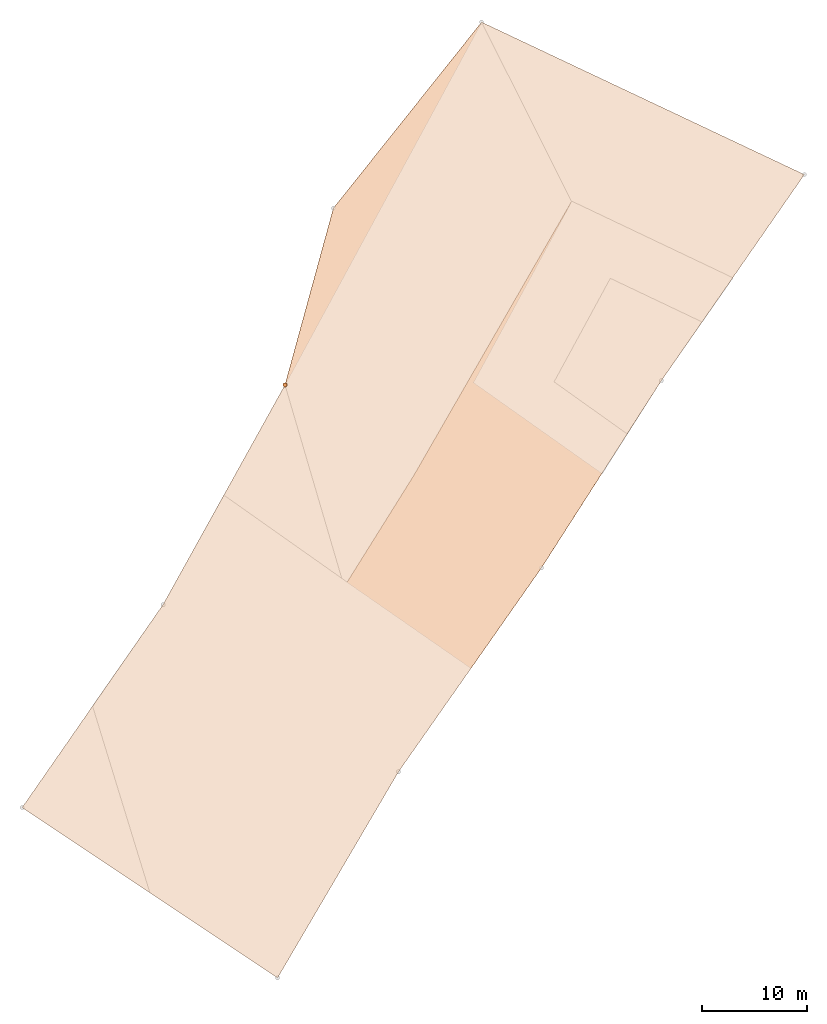
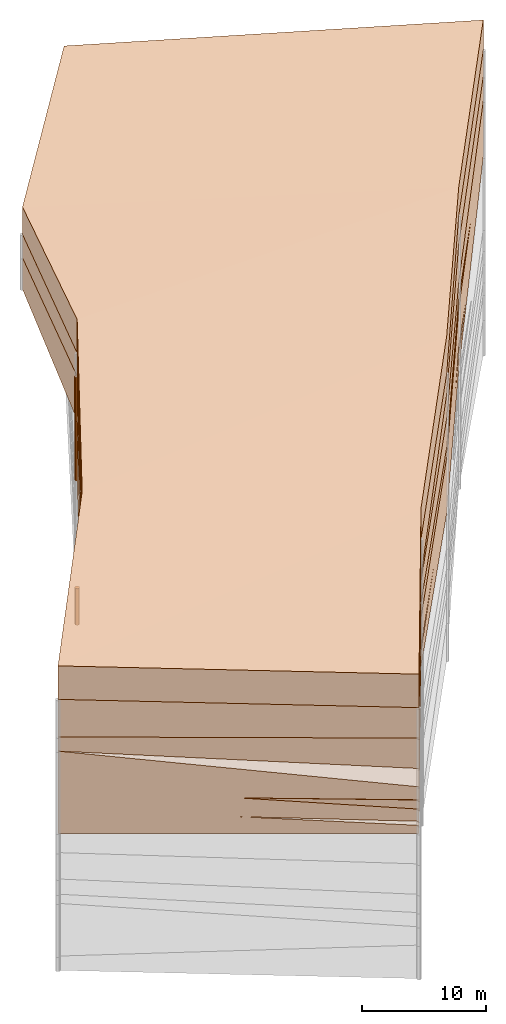
# One storey, part 11 of 24: 8 geographic elements.
"""IFC4 building model written with IfcOpenShell, lengths in metres."""

from ifc_helpers import new_model, entity, si_unit, converted_unit, frame, origin_with_axes, origin_2d_with_axis, place, context, subcontext, project, spatial, polygons, element, save


model = new_model("IFC4")

# Units and contexts
model_context = context("Model", 3, precision=1e-05, world=origin_with_axes())
plan_context = context("Plan", 2, precision=1e-05, world=origin_2d_with_axis())
body_context = subcontext(model_context, "Body", "Model", "MODEL_VIEW")
ifc_project = project(units=[converted_unit("PLANEANGLEUNIT", "degree", entity("IfcReal", 0.0174532925199433), si_unit("PLANEANGLEUNIT", "RADIAN"), dimensions=[0, 0, 0, 0, 0, 0, 0]), si_unit("AREAUNIT", "SQUARE_METRE"), si_unit("VOLUMEUNIT", "CUBIC_METRE"), si_unit("LENGTHUNIT", "METRE")], contexts=[model_context, plan_context])

# Site, building, storey
site_placement = place(None, origin_with_axes())
site = spatial("IfcSite", under=ifc_project, at=site_placement)
building_placement = place(site_placement, origin_with_axes())
building = spatial("IfcBuilding", under=site, at=building_placement, Name="Building")
storey_placement = place(building_placement, origin_with_axes())
storey = spatial("IfcBuildingStorey", under=building, at=storey_placement, Name="Storey")

# Geographic elements
geographic_element_1_placement = place(storey_placement, frame((-6.64915800094604, 19.6997184753418, 18.2000007629395), z_axis=(0.0, 0.0, 1.0), x_axis=(0.848745938684591, -0.528800843008416, 0.0)))
element("IfcGeographicElement", 1, at=geographic_element_1_placement, inside=storey, PredefinedType="NOTDEFINED", context=body_context, shape_type="Tessellation", body=[
    polygons([(-18.1491794586182, 51.726863861084, -2.20000147819519), (-18.1491794586182, 51.726863861084, 0.499999970197678), (-15.5416402816772, 74.2057571411133, -1.89999949932098), (-15.5416421890259, 74.2057647705078, 0.69999885559082), (18.1824722290039, 78.1331329345703, -1.70000064373016), (15.4567575454712, 9.51265048980713, -1.90000140666962), (16.0606708526611, -13.2039785385132, 0.69999885559082), (16.0606708526611, -13.2039785385132, -2.59999918937683), (15.4567556381226, 9.51265048980713, 1.0999983549118), (-13.130428314209, -12.3041467666626, -3.10000014305115), (-13.130428314209, -12.3041467666626, 0.199998840689659), (-11.9630832672119, 11.1625785827637, -1.99999988079071), (18.1824722290039, 78.1331253051758, 1.29999911785126), (17.0040245056152, 54.3060111999512, 1.49999809265137), (16.7409706115723, 33.1700096130371, 1.60000026226044), (-13.1695642471313, 35.035457611084, 1.19899940490723), (-11.9630851745605, 11.1625785827637, 0.999999940395355), (17.0040245056152, 54.3060111999512, -1.30000114440918), (-13.169563293457, 35.0354537963867, -2.09900069236755), (16.7409687042236, 33.1700134277344, -2.10000014305115)], [[[4, 5, 3]], [[13, 14, 18, 5]], [[11, 17, 12, 10]], [[15, 18, 14]], [[11, 9, 17]], [[20, 12, 19]], [[16, 14, 2]], [[3, 18, 1]], [[4, 14, 13]], [[18, 19, 1]], [[15, 17, 9]], [[9, 20, 15]], [[16, 2, 1, 19]], [[8, 11, 10]], [[6, 10, 12]], [[2, 3, 1]], [[7, 6, 9]], [[17, 19, 12]], [[4, 13, 5]], [[15, 20, 18]], [[11, 7, 9]], [[20, 6, 12]], [[16, 15, 14]], [[3, 5, 18]], [[4, 2, 14]], [[18, 20, 19]], [[15, 16, 17]], [[9, 6, 20]], [[8, 7, 11]], [[6, 8, 10]], [[2, 4, 3]], [[7, 8, 6]], [[17, 16, 19]]]),
])
geographic_element_2_placement = place(storey_placement, frame((-6.09105730056763, 19.0666542053223, 15.3662185668945), z_axis=(0.0, 0.0, 1.0), x_axis=(0.605714798641932, 0.795681835098781, 0.0)))
element("IfcGeographicElement", 2, at=geographic_element_2_placement, inside=storey, PredefinedType="NOTDEFINED", context=body_context, shape_type="Tessellation", body=[
    polygons([(-11.4815444946289, -16.3955001831055, -2.76621699333191), (-13.3103704452515, 12.7521448135376, -3.96621870994568), (-13.3103704452515, 12.7521467208862, -0.266218155622482), (72.5967788696289, 23.2277584075928, -1.56621730327606), (49.9726409912109, 23.725715637207, -1.66621661186218), (49.9726409912109, 23.725715637207, 0.633780658245087), (72.5967788696289, 23.2277584075928, 0.933782517910004), (79.6548538208008, -9.98253726959229, -1.46621787548065), (11.0795383453369, -13.6738271713257, -2.76621866226196), (-11.4815425872803, -16.3955001831055, 0.233782753348351), (55.8217697143555, -11.0332765579224, -1.26621794700623), (10.1628646850586, 13.7803087234497, 0.833781361579895), (11.0795373916626, -13.6738262176514, 0.933779835700989), (79.6548614501953, -9.9825325012207, 1.13378131389618), (55.8217658996582, -11.033278465271, 1.53378021717072), (33.8189010620117, 17.2098445892334, 0.734781384468079), (34.7534828186035, -12.7442312240601, 0.733781933784485), (10.1628646850586, 13.7803087234497, -3.36621809005737), (34.7534866333008, -12.7442293167114, -1.26621794700623), (33.8189010620117, 17.2098445892334, -1.56321775913239)], [[[19, 13, 9]], [[14, 11, 8]], [[20, 6, 5]], [[19, 11, 15, 17]], [[15, 7, 6]], [[2, 9, 1]], [[16, 15, 6]], [[18, 19, 9]], [[12, 17, 16]], [[20, 11, 19]], [[4, 11, 5]], [[9, 13, 10, 1]], [[10, 3, 2, 1]], [[3, 12, 18, 2]], [[12, 20, 18]], [[3, 13, 12]], [[6, 7, 4, 5]], [[7, 8, 4]], [[19, 17, 13]], [[14, 15, 11]], [[20, 16, 6]], [[15, 14, 7]], [[2, 18, 9]], [[16, 17, 15]], [[18, 20, 19]], [[12, 13, 17]], [[20, 5, 11]], [[4, 8, 11]], [[12, 16, 20]], [[3, 10, 13]], [[7, 14, 8]]]),
])
geographic_element_3_placement = place(storey_placement, frame((-5.96353912353516, 18.549129486084, 6.34844017028809), z_axis=(0.0, 0.0, 1.0), x_axis=(0.81700617141835, -0.576628923888084, 0.0)))
element("IfcGeographicElement", 3, at=geographic_element_3_placement, inside=storey, PredefinedType="NOTDEFINED", context=body_context, shape_type="Tessellation", body=[
    polygons([(-20.9974346160889, 73.7364654541016, 1.05156171321869), (-6.37303066253662, -6.42467784881592, -1.59844017028809), (-13.8074789047241, 11.0024585723877, -1.24844026565552), (-20.9974308013916, 73.736457824707, 3.25156211853027), (12.4457817077637, 79.5923690795898, -0.34843921661377), (13.6900873184204, 10.5932197570801, 3.59980535507202), (13.6618566513062, 10.9285478591919, 3.63929176330566), (13.6618566513062, 10.9285478591919, 5.75155925750732), (15.568211555481, -11.7160053253174, 1.45156145095825), (15.5682106018066, -11.7160043716431, 0.169029697775841), (-1.35994815826416, 22.8476676940918, -0.948440074920654), (13.6618566513062, 10.9285478591919, -2.74844098091125), (13.6618566513062, 10.9285478591919, -1.14844083786011), (15.5682106018066, -11.7160043716431, -0.724769651889801), (-13.626425743103, -12.4925842285156, -4.44844055175781), (0.970892786979675, -12.1042928695679, -0.298439562320709), (-13.626425743103, -12.4925842285156, 3.65155959129333), (-13.8074798583984, 11.002459526062, -2.84844017028809), (13.5865421295166, 34.6206169128418, 5.35456037521362), (-13.8074779510498, 11.0024585723877, 1.95155894756317), (13.586540222168, 34.6206169128418, -4.04243803024292), (-16.3817501068115, 34.7667770385742, -2.74144124984741), (13.6618566513062, 10.9285478591919, 2.16074848175049), (13.5865411758423, 34.6206169128418, 1.4637678861618), (12.636417388916, 55.7369003295898, 3.95156073570251), (13.5865411758423, 34.6206169128418, 2.45087766647339), (12.8929653167725, 50.0352783203125, -2.7466356754303), (12.6364221572876, 55.7369003295898, -4.7484393119812), (-16.3817501068115, 34.7667846679688, 3.15655946731567), (12.5410985946655, 67.6646423339844, 1.85155951976776), (12.5821380615234, 62.5297546386719, -2.74844026565552), (12.6358518600464, 55.8078536987305, 1.35736930370331), (12.4457817077637, 79.5923690795898, 5.15156078338623), (-4.18050241470337, 64.7366790771484, 1.85155951976776), (12.6358518600464, 55.8078536987305, 2.34575176239014), (-1.39760553836823, 34.6936988830566, 1.95155990123749), (-0.0728111788630486, 10.9655027389526, 2.90155959129333), (12.8960647583008, 49.7227897644043, -2.76844024658203), (12.6364212036133, 55.7369003295898, -3.13321948051453), (4.36350059509277, 49.758430480957, -2.74844026565552), (3.05499243736267, 60.8876571655273, -2.74844026565552), (12.6364212036133, 55.7369003295898, -2.35718083381653), (12.6355352401733, 55.8476486206055, -2.3566517829895), (12.6355361938477, 55.8476486206055, -3.14022731781006), (15.5682096481323, -11.7160015106201, -3.14843726158142), (12.6423559188843, 55.6049995422363, -2.35759830474854), (13.6518440246582, 14.0782699584961, -0.800657331943512), (13.6236047744751, 22.9614772796631, -0.948439836502075), (15.5682067871094, -11.7159986495972, -1.94843733310699), (13.6618518829346, 10.9285430908203, -0.74844092130661), (2.06520700454712, 10.9597501754761, -0.5795738697052), (-13.8074789047241, 11.0024585723877, -0.348440647125244), (-13.8074789047241, 11.0024585723877, -0.457723498344421), (15.5682039260864, -11.7159996032715, -2.34843683242798), (11.1614723205566, -11.8332214355469, -2.28806042671204), (9.8250036239624, -11.8687715530396, -2.02712678909302), (0.970889091491699, -12.1042928695679, -2.14843964576721), (13.6236114501953, 22.9593849182129, -0.948405027389526), (13.6236047744751, 22.9614791870117, -0.948439836502075), (13.6236047744751, 22.9614791870117, -0.948439836502075), (15.5682039260864, -11.7159996032715, -2.34843683242798), (13.7070989608765, 10.3910789489746, -0.776922643184662), (13.6618518829346, 10.9285430908203, -0.74844092130661), (13.6618518829346, 10.9285430908203, -0.74844092130661), (13.6618518829346, 10.9285478591919, -0.748440682888031), (13.6618280410767, 10.936182975769, -0.748567581176758), (-13.8074789047241, 11.002459526062, -0.586666285991669), (-13.8074789047241, 11.0024585723877, -0.348440676927567), (-13.8074779510498, 11.0023078918457, -1.24843442440033), (-13.7169647216797, -0.743510663509369, -0.801095187664032), (-15.0905656814575, 22.8472442626953, -0.798516094684601), (-13.8075246810913, 11.0028800964355, -1.24842429161072), (15.5681943893433, -11.7159986495972, -1.94843745231628), (15.5682048797607, -11.7159986495972, -1.94843733310699), (12.9731311798096, -11.7850313186646, -1.98399341106415), (10.2083377838135, -11.8585748672485, -2.02187466621399), (11.161473274231, -11.8332214355469, -2.28806042671204), (15.5681972503662, -11.7159996032715, -2.34843683242798), (7.8209285736084, -11.922080039978, -2.05458521842957), (0.970890402793884, -12.1042928695679, -2.14843964576721), (3.88099813461304, -12.0268831253052, -2.18831086158752), (0.97088897228241, -12.1042928695679, -2.14843964576721), (-13.8074750900269, 11.0024585723877, -1.24844026565552), (-13.8074750900269, 11.0024585723877, -1.24844026565552), (13.6235961914062, 22.9614734649658, -0.948439955711365), (13.041205406189, 10.9302129745483, -0.739403247833252), (15.5682029724121, -11.7159957885742, -1.94843721389771), (2.06520652770996, 10.9597492218018, -0.579573929309845)], [[[29, 1, 22]], [[32, 36, 24]], [[8, 6, 7]], [[25, 26, 35]], [[21, 18, 22]], [[17, 15, 16]], [[21, 24, 60]], [[48, 13, 60]], [[8, 9, 10, 6]], [[27, 24, 21]], [[19, 20, 8]], [[61, 12, 13]], [[54, 61, 13]], [[14, 49, 62]], [[62, 50, 63]], [[23, 63, 64, 24]], [[63, 50, 64]], [[24, 64, 65]], [[64, 50, 66, 65]], [[16, 23, 37]], [[37, 24, 36]], [[8, 17, 9]], [[22, 28, 21]], [[25, 29, 19]], [[19, 7, 26]], [[41, 42, 46, 40]], [[30, 32, 31]], [[18, 53, 52, 67]], [[20, 68, 52]], [[15, 17, 70]], [[6, 16, 37]], [[35, 36, 34]], [[34, 32, 30]], [[34, 30, 35]], [[4, 5, 1]], [[25, 4, 29]], [[41, 43, 42]], [[41, 31, 43]], [[41, 44, 31]], [[20, 29, 22, 18, 67, 72, 71, 68]], [[1, 28, 22]], [[13, 2, 54]], [[16, 49, 14]], [[73, 74, 16]], [[16, 10, 9]], [[76, 75, 16, 56]], [[78, 77, 45, 61]], [[61, 54, 78]], [[17, 16, 9]], [[57, 80, 82]], [[77, 55, 81]], [[32, 46, 42]], [[32, 24, 27]], [[28, 27, 21]], [[39, 27, 28]], [[32, 27, 46]], [[44, 39, 28]], [[33, 25, 30]], [[30, 25, 35]], [[31, 44, 28]], [[28, 5, 31]], [[31, 32, 43]], [[5, 30, 31]], [[33, 30, 5]], [[12, 15, 18]], [[37, 7, 6]], [[39, 40, 27]], [[37, 26, 7]], [[44, 41, 39]], [[40, 46, 27]], [[40, 27, 38]], [[42, 43, 32]], [[74, 2, 49]], [[79, 2, 76, 56]], [[2, 80, 57]], [[2, 57, 81]], [[2, 81, 55, 54]], [[48, 85, 13]], [[66, 50, 52]], [[58, 47, 66]], [[51, 52, 86]], [[50, 86, 52]], [[62, 86, 50]], [[62, 49, 87]], [[88, 2, 52]], [[3, 53, 69]], [[2, 74, 73]], [[76, 2, 73, 75]], [[2, 79, 82]], [[83, 3, 2]], [[61, 13, 2, 78]], [[2, 13, 83]], [[68, 71, 11, 52]], [[80, 2, 82]], [[77, 78, 2, 81]], [[3, 83, 84, 11]], [[11, 84, 13]], [[72, 3, 11, 71]], [[52, 53, 67]], [[70, 52, 2]], [[70, 2, 3, 69]], [[29, 4, 1]], [[32, 34, 36]], [[25, 19, 26]], [[21, 12, 18]], [[13, 12, 60]], [[12, 21, 60]], [[24, 47, 58]], [[60, 59, 13]], [[24, 58, 60]], [[13, 59, 60]], [[60, 58, 48]], [[19, 29, 20]], [[61, 45, 12]], [[62, 63, 23]], [[23, 14, 62]], [[65, 66, 24]], [[66, 47, 24]], [[16, 14, 23]], [[37, 23, 24]], [[8, 20, 17]], [[19, 8, 7]], [[69, 53, 18]], [[17, 20, 70]], [[20, 52, 70]], [[70, 69, 18]], [[70, 18, 15]], [[6, 10, 16]], [[35, 26, 36]], [[4, 33, 5]], [[25, 33, 4]], [[1, 5, 28]], [[74, 49, 16]], [[16, 75, 73]], [[55, 77, 78]], [[54, 55, 78]], [[82, 79, 16]], [[79, 56, 16]], [[15, 45, 81]], [[45, 77, 81]], [[15, 81, 57]], [[82, 16, 15]], [[82, 15, 57]], [[12, 45, 15]], [[39, 41, 40]], [[37, 36, 26]], [[48, 11, 85]], [[52, 11, 66]], [[11, 48, 58]], [[58, 66, 11]], [[88, 52, 51]], [[51, 86, 62]], [[49, 2, 87]], [[87, 88, 51]], [[51, 62, 87]], [[88, 87, 2]], [[13, 85, 11]], [[84, 83, 13]], [[3, 72, 67]], [[53, 3, 67]]]),
])
geographic_element_4_placement = place(storey_placement, frame((-6.07823514938354, 18.4122753143311, 13.8235921859741), z_axis=(0.0, 0.0, 1.0), x_axis=(0.831565969542363, -0.555425997140096, 0.0)))
element("IfcGeographicElement", 4, at=geographic_element_4_placement, inside=storey, PredefinedType="NOTDEFINED", context=body_context, shape_type="Tessellation", body=[
    polygons([(-19.0747299194336, 74.4295959472656, -4.22358989715576), (-19.0747299194336, 74.4295959472656, -0.0235910397022963), (14.5080213546753, 79.4234619140625, -2.32359099388123), (15.2811098098755, -11.9350118637085, -4.22359085083008), (13.9577665328979, 10.7510805130005, -1.72359263896942), (13.9577665328979, 10.7510805130005, -1.22359263896942), (15.2811098098755, -11.9350118637085, -1.22359085083008), (-13.9238433837891, -11.9604930877686, -3.82359194755554), (-13.9238414764404, -11.9604921340942, -2.42359256744385), (-13.5005807876587, 11.5314359664917, -1.82359206676483), (14.508017539978, 79.4234619140625, 0.0764083787798882), (14.0850687026978, 55.5709800720215, 0.276408165693283), (-20.968770980835, 51.8793678283691, -0.123591415584087), (-15.4628200531006, 35.3541107177734, -0.0205917339771986), (14.4918041229248, 34.4372482299805, 0.276408165693283), (14.0850696563721, 55.5709800720215, -3.52359080314636), (-17.2689971923828, 54.8919944763184, -4.27109956741333), (-15.462818145752, 35.3541069030762, -4.31859159469604), (14.4918022155762, 34.4372482299805, -2.12059116363525), (-20.9687690734863, 51.8793678283691, -3.22359013557434)], [[[12, 19, 16]], [[9, 6, 10]], [[12, 3, 11]], [[10, 15, 14]], [[5, 8, 10]], [[2, 12, 11]], [[16, 18, 17]], [[19, 10, 18]], [[16, 1, 3]], [[14, 12, 13]], [[2, 11, 3, 1]], [[14, 13, 20, 18]], [[6, 7, 4, 5]], [[9, 10, 8]], [[10, 14, 18]], [[15, 6, 5, 19]], [[8, 4, 7, 9]], [[1, 17, 20]], [[20, 17, 18]], [[2, 20, 13]], [[12, 15, 19]], [[9, 7, 6]], [[12, 16, 3]], [[10, 6, 15]], [[5, 4, 8]], [[2, 13, 12]], [[16, 19, 18]], [[19, 5, 10]], [[16, 17, 1]], [[14, 15, 12]], [[2, 1, 20]]]),
])
geographic_element_5_placement = place(storey_placement, frame((-5.96353912353516, 18.549129486084, 6.34844017028809), z_axis=(0.0, 0.0, 1.0), x_axis=(0.806372566444084, -0.591407883010009, 0.0)))
element("IfcGeographicElement", 5, at=geographic_element_5_placement, inside=storey, PredefinedType="NOTDEFINED", context=body_context, shape_type="Tessellation", body=[
    polygons([(11.3071136474609, 67.8817520141602, 1.85155951976776), (11.619574546814, 55.9577178955078, 1.35156059265137), (11.619574546814, 55.9577178955078, 2.35156059265137), (15.7789316177368, -11.430624961853, -0.748437881469727), (13.4606266021729, 11.1754655838013, 2.1515588760376), (13.4606266021729, 11.1754665374756, 3.6515588760376), (15.7789316177368, -11.430624961853, 0.151561722159386), (1.1911039352417, -12.0846128463745, -0.298439979553223), (-0.272438019514084, 10.9623594284058, 2.90155959129333), (12.9539842605591, 34.8622398376465, 2.4575617313385), (-2.0290105342865, 34.6625022888184, 1.95155990123749), (-5.35841178894043, 64.6498336791992, 1.85155951976776), (12.9539813995361, 34.8622436523438, 1.45756137371063)], [[[1, 3, 2]], [[2, 11, 12]], [[8, 4, 7]], [[6, 7, 4, 5]], [[5, 8, 9]], [[3, 11, 10]], [[10, 5, 13]], [[12, 1, 2]], [[12, 3, 1]], [[8, 6, 9]], [[9, 10, 11]], [[13, 9, 11]], [[3, 13, 2]], [[2, 13, 11]], [[5, 4, 8]], [[3, 12, 11]], [[10, 6, 5]], [[8, 7, 6]], [[9, 6, 10]], [[13, 5, 9]], [[3, 10, 13]]]),
])
geographic_element_6_placement = place(storey_placement, frame((0.699999988079071, 56.4000015258789, 6.55599975585938), z_axis=(0.0, 0.0, 1.0), x_axis=(1.0, 0.0, 0.0)))
element("IfcGeographicElement", 6, at=geographic_element_6_placement, inside=storey, PredefinedType="NOTDEFINED", context=body_context, shape_type="Tessellation", body=[
    polygons([(0.0, 0.0, -2.94899988174438), (0.0390180610120296, 0.196157038211823, -2.94899988174438), (0.0, 0.199999988079071, -2.94899988174438), (0.0, 0.0, 2.94899988174438), (0.0, 0.199999988079071, 2.94899988174438), (0.0390180610120296, 0.196157038211823, 2.94899988174438), (0.0765366926789284, 0.18477588891983, -2.94899988174438), (0.0765366926789284, 0.18477588891983, 2.94899988174438), (0.111114047467709, 0.166293919086456, -2.94899988174438), (0.111114047467709, 0.166293919086456, 2.94899988174438), (0.141421362757683, 0.141421362757683, -2.94899988174438), (0.141421362757683, 0.141421362757683, 2.94899988174438), (0.166293919086456, 0.111114047467709, -2.94899988174438), (0.166293919086456, 0.111114047467709, 2.94899988174438), (0.18477588891983, 0.0765366926789284, -2.94899988174438), (0.18477588891983, 0.0765366926789284, 2.94899988174438), (0.196157038211823, 0.0390180610120296, -2.94899988174438), (0.196157038211823, 0.0390180610120296, 2.94899988174438), (0.199999988079071, 0.0, -2.94899988174438), (0.199999988079071, 0.0, 2.94899988174438), (0.196157038211823, -0.0390180610120296, -2.94899988174438), (0.196157038211823, -0.0390180610120296, 2.94899988174438), (0.18477588891983, -0.0765366926789284, -2.94899988174438), (0.18477588891983, -0.0765366926789284, 2.94899988174438), (0.166293919086456, -0.111114047467709, -2.94899988174438), (0.166293919086456, -0.111114047467709, 2.94899988174438), (0.141421362757683, -0.141421362757683, -2.94899988174438), (0.141421362757683, -0.141421362757683, 2.94899988174438), (0.111114047467709, -0.166293919086456, -2.94899988174438), (0.111114047467709, -0.166293919086456, 2.94899988174438), (0.0765366926789284, -0.18477588891983, -2.94899988174438), (0.0765366926789284, -0.18477588891983, 2.94899988174438), (0.0390180610120296, -0.196157038211823, -2.94899988174438), (0.0390180610120296, -0.196157038211823, 2.94899988174438), (0.0, -0.199999988079071, -2.94899988174438), (0.0, -0.199999988079071, 2.94899988174438), (-0.0390180610120296, -0.196157038211823, -2.94899988174438), (-0.0390180610120296, -0.196157038211823, 2.94899988174438), (-0.0765366926789284, -0.18477588891983, -2.94899988174438), (-0.0765366926789284, -0.18477588891983, 2.94899988174438), (-0.111114047467709, -0.166293919086456, -2.94899988174438), (-0.111114047467709, -0.166293919086456, 2.94899988174438), (-0.141421362757683, -0.141421362757683, -2.94899988174438), (-0.141421362757683, -0.141421362757683, 2.94899988174438), (-0.166293919086456, -0.111114047467709, -2.94899988174438), (-0.166293919086456, -0.111114047467709, 2.94899988174438), (-0.18477588891983, -0.0765366926789284, -2.94899988174438), (-0.18477588891983, -0.0765366926789284, 2.94899988174438), (-0.196157038211823, -0.0390180610120296, -2.94899988174438), (-0.196157038211823, -0.0390180610120296, 2.94899988174438), (-0.199999988079071, 0.0, -2.94899988174438), (-0.199999988079071, 0.0, 2.94899988174438), (-0.196157038211823, 0.0390180610120296, -2.94899988174438), (-0.196157038211823, 0.0390180610120296, 2.94899988174438), (-0.18477588891983, 0.0765366926789284, -2.94899988174438), (-0.18477588891983, 0.0765366926789284, 2.94899988174438), (-0.166293919086456, 0.111114047467709, -2.94899988174438), (-0.166293919086456, 0.111114047467709, 2.94899988174438), (-0.141421362757683, 0.141421362757683, -2.94899988174438), (-0.141421362757683, 0.141421362757683, 2.94899988174438), (-0.111114047467709, 0.166293919086456, -2.94899988174438), (-0.111114047467709, 0.166293919086456, 2.94899988174438), (-0.0765366926789284, 0.18477588891983, -2.94899988174438), (-0.0765366926789284, 0.18477588891983, 2.94899988174438), (-0.0390180610120296, 0.196157038211823, -2.94899988174438), (-0.0390180610120296, 0.196157038211823, 2.94899988174438)], [[[3, 2, 1]], [[6, 5, 4]], [[28, 30, 29, 27]], [[2, 7, 1]], [[8, 6, 4]], [[36, 38, 37, 35]], [[7, 9, 1]], [[10, 8, 4]], [[56, 58, 57, 55]], [[9, 11, 1]], [[12, 10, 4]], [[58, 60, 59, 57]], [[11, 13, 1]], [[12, 4, 14]], [[54, 56, 55, 53]], [[1, 13, 15]], [[14, 4, 16]], [[10, 12, 11, 9]], [[1, 15, 17]], [[4, 18, 16]], [[60, 62, 61, 59]], [[1, 17, 19]], [[4, 20, 18]], [[16, 18, 17, 15]], [[1, 19, 21]], [[20, 4, 22]], [[18, 20, 19, 17]], [[1, 21, 23]], [[4, 24, 22]], [[20, 22, 21, 19]], [[1, 23, 25]], [[24, 4, 26]], [[22, 24, 23, 21]], [[27, 1, 25]], [[26, 4, 28]], [[24, 26, 25, 23]], [[1, 27, 29]], [[28, 4, 30]], [[62, 64, 63, 61]], [[1, 29, 31]], [[4, 32, 30]], [[64, 66, 65, 63]], [[1, 31, 33]], [[4, 34, 32]], [[30, 32, 31, 29]], [[1, 33, 35]], [[4, 36, 34]], [[8, 10, 9, 7]], [[1, 35, 37]], [[4, 38, 36]], [[32, 34, 33, 31]], [[1, 37, 39]], [[4, 40, 38]], [[6, 8, 7, 2]], [[1, 39, 41]], [[4, 42, 40]], [[38, 40, 39, 37]], [[43, 1, 41]], [[4, 44, 42]], [[40, 42, 41, 39]], [[45, 1, 43]], [[46, 44, 4]], [[42, 44, 43, 41]], [[47, 1, 45]], [[4, 48, 46]], [[44, 46, 45, 43]], [[47, 49, 1]], [[50, 48, 4]], [[46, 48, 47, 45]], [[51, 1, 49]], [[52, 50, 4]], [[48, 50, 49, 47]], [[51, 53, 1]], [[4, 54, 52]], [[66, 5, 3, 65]], [[53, 55, 1]], [[56, 54, 4]], [[52, 54, 53, 51]], [[57, 1, 55]], [[4, 58, 56]], [[57, 59, 1]], [[60, 58, 4]], [[34, 36, 35, 33]], [[59, 61, 1]], [[62, 60, 4]], [[14, 16, 15, 13]], [[61, 63, 1]], [[64, 62, 4]], [[26, 28, 27, 25]], [[63, 65, 1]], [[66, 64, 4]], [[5, 6, 2, 3]], [[65, 3, 1]], [[5, 66, 4]], [[50, 52, 51, 49]], [[12, 14, 13, 11]]]),
])
geographic_element_7_placement = place(storey_placement, frame((0.699999988079071, 56.4000015258789, 11.6540002822876), z_axis=(0.0, 0.0, 1.0), x_axis=(1.0, 0.0, 0.0)))
element("IfcGeographicElement", 7, at=geographic_element_7_placement, inside=storey, PredefinedType="NOTDEFINED", context=body_context, shape_type="Tessellation", body=[
    polygons([(0.0, 0.0, -2.1489999294281), (0.0390180610120296, 0.196157038211823, -2.1489999294281), (0.0, 0.199999988079071, -2.1489999294281), (0.0, 0.0, 2.1489999294281), (0.0, 0.199999988079071, 2.1489999294281), (0.0390180610120296, 0.196157038211823, 2.1489999294281), (0.0765366926789284, 0.18477588891983, -2.1489999294281), (0.0765366926789284, 0.18477588891983, 2.1489999294281), (0.111114047467709, 0.166293919086456, -2.1489999294281), (0.111114047467709, 0.166293919086456, 2.1489999294281), (0.141421362757683, 0.141421362757683, -2.1489999294281), (0.141421362757683, 0.141421362757683, 2.1489999294281), (0.166293919086456, 0.111114047467709, -2.1489999294281), (0.166293919086456, 0.111114047467709, 2.1489999294281), (0.18477588891983, 0.0765366926789284, -2.1489999294281), (0.18477588891983, 0.0765366926789284, 2.1489999294281), (0.196157038211823, 0.0390180610120296, -2.1489999294281), (0.196157038211823, 0.0390180610120296, 2.1489999294281), (0.199999988079071, 0.0, -2.1489999294281), (0.199999988079071, 0.0, 2.1489999294281), (0.196157038211823, -0.0390180610120296, -2.1489999294281), (0.196157038211823, -0.0390180610120296, 2.1489999294281), (0.18477588891983, -0.0765366926789284, -2.1489999294281), (0.18477588891983, -0.0765366926789284, 2.1489999294281), (0.166293919086456, -0.111114047467709, -2.1489999294281), (0.166293919086456, -0.111114047467709, 2.1489999294281), (0.141421362757683, -0.141421362757683, -2.1489999294281), (0.141421362757683, -0.141421362757683, 2.1489999294281), (0.111114047467709, -0.166293919086456, -2.1489999294281), (0.111114047467709, -0.166293919086456, 2.1489999294281), (0.0765366926789284, -0.18477588891983, -2.1489999294281), (0.0765366926789284, -0.18477588891983, 2.1489999294281), (0.0390180610120296, -0.196157038211823, -2.1489999294281), (0.0390180610120296, -0.196157038211823, 2.1489999294281), (0.0, -0.199999988079071, -2.1489999294281), (0.0, -0.199999988079071, 2.1489999294281), (-0.0390180610120296, -0.196157038211823, -2.1489999294281), (-0.0390180610120296, -0.196157038211823, 2.1489999294281), (-0.0765366926789284, -0.18477588891983, -2.1489999294281), (-0.0765366926789284, -0.18477588891983, 2.1489999294281), (-0.111114047467709, -0.166293919086456, -2.1489999294281), (-0.111114047467709, -0.166293919086456, 2.1489999294281), (-0.141421362757683, -0.141421362757683, -2.1489999294281), (-0.141421362757683, -0.141421362757683, 2.1489999294281), (-0.166293919086456, -0.111114047467709, -2.1489999294281), (-0.166293919086456, -0.111114047467709, 2.1489999294281), (-0.18477588891983, -0.0765366926789284, -2.1489999294281), (-0.18477588891983, -0.0765366926789284, 2.1489999294281), (-0.196157038211823, -0.0390180610120296, -2.1489999294281), (-0.196157038211823, -0.0390180610120296, 2.1489999294281), (-0.199999988079071, 0.0, -2.1489999294281), (-0.199999988079071, 0.0, 2.1489999294281), (-0.196157038211823, 0.0390180610120296, -2.1489999294281), (-0.196157038211823, 0.0390180610120296, 2.1489999294281), (-0.18477588891983, 0.0765366926789284, -2.1489999294281), (-0.18477588891983, 0.0765366926789284, 2.1489999294281), (-0.166293919086456, 0.111114047467709, -2.1489999294281), (-0.166293919086456, 0.111114047467709, 2.1489999294281), (-0.141421362757683, 0.141421362757683, -2.1489999294281), (-0.141421362757683, 0.141421362757683, 2.1489999294281), (-0.111114047467709, 0.166293919086456, -2.1489999294281), (-0.111114047467709, 0.166293919086456, 2.1489999294281), (-0.0765366926789284, 0.18477588891983, -2.1489999294281), (-0.0765366926789284, 0.18477588891983, 2.1489999294281), (-0.0390180610120296, 0.196157038211823, -2.1489999294281), (-0.0390180610120296, 0.196157038211823, 2.1489999294281)], [[[3, 2, 1]], [[6, 5, 4]], [[28, 30, 29, 27]], [[2, 7, 1]], [[8, 6, 4]], [[64, 66, 65, 63]], [[7, 9, 1]], [[10, 8, 4]], [[9, 11, 1]], [[12, 10, 4]], [[6, 8, 7, 2]], [[1, 11, 13]], [[12, 4, 14]], [[66, 5, 3, 65]], [[1, 13, 15]], [[4, 16, 14]], [[12, 14, 13, 11]], [[1, 15, 17]], [[4, 18, 16]], [[14, 16, 15, 13]], [[1, 17, 19]], [[4, 20, 18]], [[16, 18, 17, 15]], [[1, 19, 21]], [[4, 22, 20]], [[18, 20, 19, 17]], [[1, 21, 23]], [[22, 4, 24]], [[20, 22, 21, 19]], [[1, 23, 25]], [[4, 26, 24]], [[22, 24, 23, 21]], [[27, 1, 25]], [[4, 28, 26]], [[24, 26, 25, 23]], [[1, 27, 29]], [[28, 4, 30]], [[26, 28, 27, 25]], [[1, 29, 31]], [[4, 32, 30]], [[5, 6, 2, 3]], [[1, 31, 33]], [[4, 34, 32]], [[30, 32, 31, 29]], [[1, 33, 35]], [[4, 36, 34]], [[8, 10, 9, 7]], [[1, 35, 37]], [[4, 38, 36]], [[32, 34, 33, 31]], [[1, 37, 39]], [[4, 40, 38]], [[36, 38, 37, 35]], [[1, 39, 41]], [[4, 42, 40]], [[38, 40, 39, 37]], [[43, 1, 41]], [[4, 44, 42]], [[40, 42, 41, 39]], [[43, 45, 1]], [[46, 44, 4]], [[42, 44, 43, 41]], [[45, 47, 1]], [[48, 46, 4]], [[44, 46, 45, 43]], [[49, 1, 47]], [[50, 48, 4]], [[46, 48, 47, 45]], [[49, 51, 1]], [[52, 50, 4]], [[48, 50, 49, 47]], [[51, 53, 1]], [[54, 52, 4]], [[50, 52, 51, 49]], [[53, 55, 1]], [[4, 56, 54]], [[52, 54, 53, 51]], [[55, 57, 1]], [[58, 56, 4]], [[54, 56, 55, 53]], [[57, 59, 1]], [[60, 58, 4]], [[56, 58, 57, 55]], [[59, 61, 1]], [[62, 60, 4]], [[58, 60, 59, 57]], [[61, 63, 1]], [[64, 62, 4]], [[60, 62, 61, 59]], [[63, 65, 1]], [[66, 64, 4]], [[62, 64, 63, 61]], [[65, 3, 1]], [[5, 66, 4]], [[34, 36, 35, 33]], [[10, 12, 11, 9]]]),
])
geographic_element_8_placement = place(storey_placement, frame((0.700000047683716, 56.4000015258789, -8.79000282287598), z_axis=(0.0, 0.0, 1.0), x_axis=(1.0, 0.0, 0.0)))
element("IfcGeographicElement", 8, at=geographic_element_8_placement, inside=storey, PredefinedType="NOTDEFINED", context=body_context, shape_type="Tessellation", body=[
    polygons([(0.0, 0.0, -1.80000007152557), (0.0390180610120296, 0.196157038211823, -1.80000007152557), (0.0, 0.199999988079071, -1.80000007152557), (0.0, 0.0, 1.80000007152557), (0.0, 0.199999988079071, 1.80000007152557), (0.0390180610120296, 0.196157038211823, 1.80000007152557), (0.0765366926789284, 0.18477588891983, -1.80000007152557), (0.0765366926789284, 0.18477588891983, 1.80000007152557), (0.111114047467709, 0.166293919086456, -1.80000007152557), (0.111114047467709, 0.166293919086456, 1.80000007152557), (0.141421362757683, 0.141421362757683, -1.80000007152557), (0.141421362757683, 0.141421362757683, 1.80000007152557), (0.166293919086456, 0.111114047467709, -1.80000007152557), (0.166293919086456, 0.111114047467709, 1.80000007152557), (0.18477588891983, 0.0765366926789284, -1.80000007152557), (0.18477588891983, 0.0765366926789284, 1.80000007152557), (0.196157038211823, 0.0390180610120296, -1.80000007152557), (0.196157038211823, 0.0390180610120296, 1.80000007152557), (0.199999988079071, 0.0, -1.80000007152557), (0.199999988079071, 0.0, 1.80000007152557), (0.196157038211823, -0.0390180610120296, -1.80000007152557), (0.196157038211823, -0.0390180610120296, 1.80000007152557), (0.18477588891983, -0.0765366926789284, -1.80000007152557), (0.18477588891983, -0.0765366926789284, 1.80000007152557), (0.166293919086456, -0.111114047467709, -1.80000007152557), (0.166293919086456, -0.111114047467709, 1.80000007152557), (0.141421362757683, -0.141421362757683, -1.80000007152557), (0.141421362757683, -0.141421362757683, 1.80000007152557), (0.111114047467709, -0.166293919086456, -1.80000007152557), (0.111114047467709, -0.166293919086456, 1.80000007152557), (0.0765366926789284, -0.18477588891983, -1.80000007152557), (0.0765366926789284, -0.18477588891983, 1.80000007152557), (0.0390180610120296, -0.196157038211823, -1.80000007152557), (0.0390180610120296, -0.196157038211823, 1.80000007152557), (0.0, -0.199999988079071, -1.80000007152557), (0.0, -0.199999988079071, 1.80000007152557), (-0.0390180610120296, -0.196157038211823, -1.80000007152557), (-0.0390180610120296, -0.196157038211823, 1.80000007152557), (-0.0765366926789284, -0.18477588891983, -1.80000007152557), (-0.0765366926789284, -0.18477588891983, 1.80000007152557), (-0.111114047467709, -0.166293919086456, -1.80000007152557), (-0.111114047467709, -0.166293919086456, 1.80000007152557), (-0.141421362757683, -0.141421362757683, -1.80000007152557), (-0.141421362757683, -0.141421362757683, 1.80000007152557), (-0.166293919086456, -0.111114047467709, -1.80000007152557), (-0.166293919086456, -0.111114047467709, 1.80000007152557), (-0.18477588891983, -0.0765366926789284, -1.80000007152557), (-0.18477588891983, -0.0765366926789284, 1.80000007152557), (-0.196157038211823, -0.0390180610120296, -1.80000007152557), (-0.196157038211823, -0.0390180610120296, 1.80000007152557), (-0.199999988079071, 0.0, -1.80000007152557), (-0.199999988079071, 0.0, 1.80000007152557), (-0.196157038211823, 0.0390180610120296, -1.80000007152557), (-0.196157038211823, 0.0390180610120296, 1.80000007152557), (-0.18477588891983, 0.0765366926789284, -1.80000007152557), (-0.18477588891983, 0.0765366926789284, 1.80000007152557), (-0.166293919086456, 0.111114047467709, -1.80000007152557), (-0.166293919086456, 0.111114047467709, 1.80000007152557), (-0.141421362757683, 0.141421362757683, -1.80000007152557), (-0.141421362757683, 0.141421362757683, 1.80000007152557), (-0.111114047467709, 0.166293919086456, -1.80000007152557), (-0.111114047467709, 0.166293919086456, 1.80000007152557), (-0.0765366926789284, 0.18477588891983, -1.80000007152557), (-0.0765366926789284, 0.18477588891983, 1.80000007152557), (-0.0390180610120296, 0.196157038211823, -1.80000007152557), (-0.0390180610120296, 0.196157038211823, 1.80000007152557)], [[[3, 2, 1]], [[6, 5, 4]], [[62, 64, 63, 61]], [[2, 7, 1]], [[8, 6, 4]], [[64, 66, 65, 63]], [[7, 9, 1]], [[10, 8, 4]], [[32, 34, 33, 31]], [[9, 11, 1]], [[12, 10, 4]], [[34, 36, 35, 33]], [[11, 13, 1]], [[12, 4, 14]], [[30, 32, 31, 29]], [[1, 13, 15]], [[4, 16, 14]], [[36, 38, 37, 35]], [[1, 15, 17]], [[4, 18, 16]], [[40, 42, 41, 39]], [[1, 17, 19]], [[4, 20, 18]], [[44, 46, 45, 43]], [[1, 19, 21]], [[4, 22, 20]], [[48, 50, 49, 47]], [[1, 21, 23]], [[4, 24, 22]], [[50, 52, 51, 49]], [[1, 23, 25]], [[4, 26, 24]], [[52, 54, 53, 51]], [[27, 1, 25]], [[26, 4, 28]], [[58, 60, 59, 57]], [[1, 27, 29]], [[28, 4, 30]], [[60, 62, 61, 59]], [[1, 29, 31]], [[4, 32, 30]], [[66, 5, 3, 65]], [[1, 31, 33]], [[4, 34, 32]], [[1, 33, 35]], [[4, 36, 34]], [[8, 10, 9, 7]], [[1, 35, 37]], [[4, 38, 36]], [[10, 12, 11, 9]], [[1, 37, 39]], [[4, 40, 38]], [[14, 16, 15, 13]], [[1, 39, 41]], [[4, 42, 40]], [[38, 40, 39, 37]], [[43, 1, 41]], [[4, 44, 42]], [[16, 18, 17, 15]], [[45, 1, 43]], [[46, 44, 4]], [[42, 44, 43, 41]], [[45, 47, 1]], [[48, 46, 4]], [[18, 20, 19, 17]], [[47, 49, 1]], [[50, 48, 4]], [[46, 48, 47, 45]], [[49, 51, 1]], [[52, 50, 4]], [[20, 22, 21, 19]], [[51, 53, 1]], [[54, 52, 4]], [[22, 24, 23, 21]], [[53, 55, 1]], [[56, 54, 4]], [[24, 26, 25, 23]], [[55, 57, 1]], [[58, 56, 4]], [[54, 56, 55, 53]], [[57, 59, 1]], [[60, 58, 4]], [[56, 58, 57, 55]], [[59, 61, 1]], [[62, 60, 4]], [[26, 28, 27, 25]], [[61, 63, 1]], [[64, 62, 4]], [[28, 30, 29, 27]], [[63, 65, 1]], [[66, 64, 4]], [[5, 6, 2, 3]], [[65, 3, 1]], [[5, 66, 4]], [[6, 8, 7, 2]], [[12, 14, 13, 11]]]),
])

save(model, "model.ifc")
